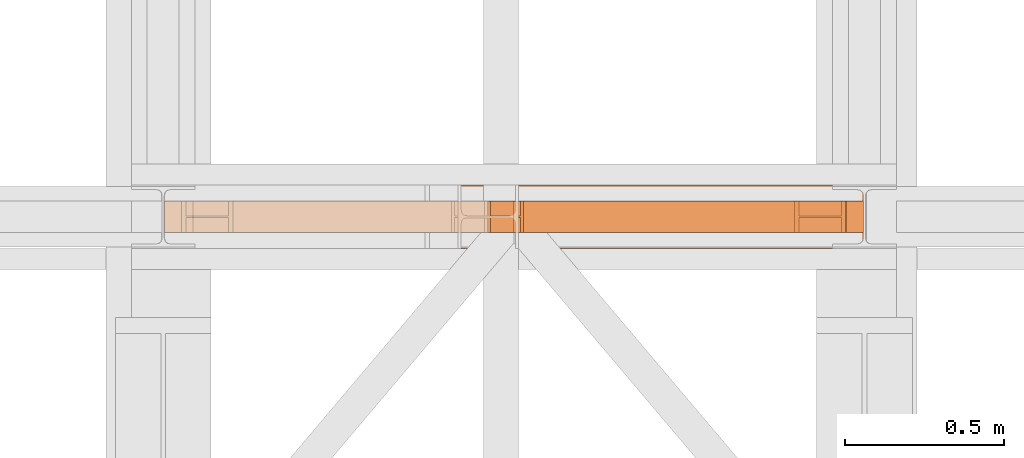
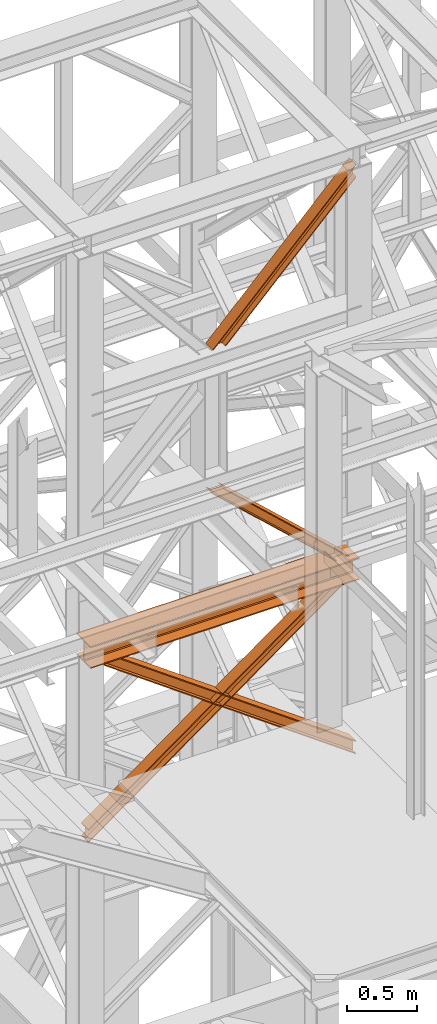
# One storey, part 110 of 208: 5 proxies.
"""IFC2X3 building model written with IfcOpenShell, lengths in millimetres."""

from ifc_helpers import new_model, entity, si_unit, converted_unit, frame, origin, origin_with_axes, place, context, subcontext, project, spatial, faceted_brep, element, save


model = new_model("IFC2X3")

# Units and contexts
model_context = context("Model", 3, precision=1e-05, world=origin())
plan_context = context("Plan", 3, precision=1e-05, world=origin())
body_context = subcontext(model_context, "Body", "Model", "MODEL_VIEW")
ifc_project = project(units=[si_unit("LENGTHUNIT", "METRE", prefix="MILLI"), converted_unit("PLANEANGLEUNIT", "DEGREE", entity("IfcPlaneAngleMeasure", 0.0174532925199433), si_unit("PLANEANGLEUNIT", "RADIAN"), dimensions=[0, 0, 0, 0, 0, 0, 0]), si_unit("AREAUNIT", "SQUARE_METRE"), si_unit("VOLUMEUNIT", "CUBIC_METRE")], contexts=[model_context, plan_context])

# Building, storey
building_placement = place(None, origin())
building = spatial("IfcBuilding", under=ifc_project, at=building_placement, CompositionType="COMPLEX")
storey_placement = place(building_placement, origin_with_axes())
storey = spatial("IfcBuildingStorey", under=building, at=storey_placement, Name="Geschoss", CompositionType="ELEMENT")

# Proxies
proxy_1_placement = place(storey_placement, frame((-14.99503153838828, -16062.574391808, 8678.7992121432), z_axis=(0.0, 0.0, 1.0), x_axis=(1.0, 0.0, 0.0)))
element("IfcBuildingElementProxy", 1, at=proxy_1_placement, inside=storey, context=body_context, shape_type="Brep", body=[
    faceted_brep([(0.009999999999990905, 0.01000000000021828, 0.01000000000021828), (0.009999999999990905, 200.0100029802325, 0.01000000000021828), (0.009999999999990905, 200.0100029802325, 10.00999791383765), (0.009999999999990905, 121.2600035762789, 10.01000536441825), (0.009999999999990905, 111.9441915473344, 11.87455041170142), (0.009999999999990905, 105.1245498640838, 18.69419349193595), (0.009999999999990905, 103.2600015571716, 28.01000458955787), (0.009999999999990905, 103.2600015571716, 162.0100153779986), (0.009999999999990905, 105.1245498640838, 171.3258264756205), (0.009999999999990905, 111.9441915473344, 178.145469555855), (0.009999999999990905, 121.2600035762789, 180.0100146031382), (0.009999999999990905, 200.0100029802325, 180.0100146031382), (0.009999999999990905, 200.0100029802325, 190.0100125169756), (0.009999999999990905, 0.01000000000021828, 190.0100125169756), (0.009999999999990905, 0.01000000000021828, 180.0100146031382), (0.009999999999990905, 78.75999940395377, 180.0100146031382), (0.009999999999990905, 88.07581143289826, 178.145469555855), (0.009999999999990905, 94.89545311614893, 171.3258264756205), (0.009999999999990905, 96.76000142306111, 162.0100153779986), (0.009999999999990905, 96.76000142306111, 28.01000458955787), (0.009999999999990905, 94.89545311614893, 18.69419349193595), (0.009999999999990905, 88.07581143289826, 11.87455041170142), (0.009999999999990905, 78.75999940395377, 10.01000536441825), (0.009999999999990905, 0.01000000000021828, 10.00999791383765), (0.009999999999990905, 200.0100029802325, 0.01000000000021828), (0.009999999999990905, 0.01000000000021828, 0.01000000000021828), (2205.009999999998, 0.00999999999839929, 0.01000000000021828), (2205.009999999998, 200.0100029802306, 0.01000000000021828), (0.009999999999990905, 200.0100029802325, 10.00999791383765), (0.009999999999990905, 200.0100029802325, 0.01000000000021828), (2205.009999999998, 200.0100029802306, 0.01000000000021828), (2205.009999999998, 200.0100029802306, 10.00999791383765), (0.009999999999990905, 121.2600035762789, 10.01000536441825), (0.009999999999990905, 200.0100029802325, 10.00999791383765), (2205.009999999998, 200.0100029802306, 10.00999791383765), (2205.009999999998, 121.2600035762771, 10.01000536441825), (0.009999999999990905, 111.9441915473344, 11.87455041170142), (0.009999999999990905, 121.2600035762789, 10.01000536441825), (2205.009999999998, 121.2600035762771, 10.01000536441825), (2205.009999999998, 111.9441915473326, 11.87455041170142), (0.009999999999990905, 105.1245498640838, 18.69419349193595), (0.009999999999990905, 111.9441915473344, 11.87455041170142), (2205.009999999998, 111.9441915473326, 11.87455041170142), (2205.009999999998, 105.1245498640819, 18.69419349193595), (0.009999999999990905, 103.2600015571716, 28.01000458955787), (0.009999999999990905, 105.1245498640838, 18.69419349193595), (2205.009999999998, 105.1245498640819, 18.69419349193595), (2205.009999999998, 103.2600015571697, 28.01000458955787), (0.009999999999990905, 103.2600015571716, 162.0100153779986), (0.009999999999990905, 103.2600015571716, 28.01000458955787), (2205.009999999998, 103.2600015571697, 28.01000458955787), (2205.009999999998, 103.2600015571697, 162.0100153779986), (0.009999999999990905, 105.1245498640838, 171.3258264756205), (0.009999999999990905, 103.2600015571716, 162.0100153779986), (2205.009999999998, 103.2600015571697, 162.0100153779986), (2205.009999999998, 105.1245498640819, 171.3258264756205), (0.009999999999990905, 111.9441915473344, 178.145469555855), (0.009999999999990905, 105.1245498640838, 171.3258264756205), (2205.009999999998, 105.1245498640819, 171.3258264756205), (2205.009999999998, 111.9441915473326, 178.145469555855), (0.009999999999990905, 121.2600035762789, 180.0100146031382), (0.009999999999990905, 111.9441915473344, 178.145469555855), (2205.009999999998, 111.9441915473326, 178.145469555855), (2205.009999999998, 121.2600035762771, 180.0100146031382), (0.009999999999990905, 200.0100029802325, 180.0100146031382), (0.009999999999990905, 121.2600035762789, 180.0100146031382), (2205.009999999998, 121.2600035762771, 180.0100146031382), (2205.009999999998, 200.0100029802306, 180.0100146031382), (0.009999999999990905, 200.0100029802325, 190.0100125169756), (0.009999999999990905, 200.0100029802325, 180.0100146031382), (2205.009999999998, 200.0100029802306, 180.0100146031382), (2205.009999999998, 200.0100029802306, 190.0100125169756), (0.009999999999990905, 0.01000000000021828, 190.0100125169756), (0.009999999999990905, 200.0100029802325, 190.0100125169756), (2205.009999999998, 200.0100029802306, 190.0100125169756), (2205.009999999998, 0.00999999999839929, 190.0100125169756), (0.009999999999990905, 0.01000000000021828, 180.0100146031382), (0.009999999999990905, 0.01000000000021828, 190.0100125169756), (2205.009999999998, 0.00999999999839929, 190.0100125169756), (2205.009999999998, 0.00999999999839929, 180.0100146031382), (0.009999999999990905, 78.75999940395377, 180.0100146031382), (0.009999999999990905, 0.01000000000021828, 180.0100146031382), (2205.009999999998, 0.00999999999839929, 180.0100146031382), (2205.009999999998, 78.75999940395195, 180.0100146031382), (0.009999999999990905, 88.07581143289826, 178.145469555855), (0.009999999999990905, 78.75999940395377, 180.0100146031382), (2205.009999999998, 78.75999940395195, 180.0100146031382), (2205.009999999998, 88.07581143289644, 178.145469555855), (0.009999999999990905, 94.89545311614893, 171.3258264756205), (0.009999999999990905, 88.07581143289826, 178.145469555855), (2205.009999999998, 88.07581143289644, 178.145469555855), (2205.009999999998, 94.89545311614711, 171.3258264756205), (0.009999999999990905, 96.76000142306111, 162.0100153779986), (0.009999999999990905, 94.89545311614893, 171.3258264756205), (2205.009999999998, 94.89545311614711, 171.3258264756205), (2205.009999999998, 96.7600014230593, 162.0100153779986), (0.009999999999990905, 96.76000142306111, 28.01000458955787), (0.009999999999990905, 96.76000142306111, 162.0100153779986), (2205.009999999998, 96.7600014230593, 162.0100153779986), (2205.009999999998, 96.7600014230593, 28.01000458955787), (0.009999999999990905, 94.89545311614893, 18.69419349193595), (0.009999999999990905, 96.76000142306111, 28.01000458955787), (2205.009999999998, 96.7600014230593, 28.01000458955787), (2205.009999999998, 94.89545311614711, 18.69419349193595), (0.009999999999990905, 88.07581143289826, 11.87455041170142), (0.009999999999990905, 94.89545311614893, 18.69419349193595), (2205.009999999998, 94.89545311614711, 18.69419349193595), (2205.009999999998, 88.07581143289644, 11.87455041170142), (0.009999999999990905, 78.75999940395377, 10.01000536441825), (0.009999999999990905, 88.07581143289826, 11.87455041170142), (2205.009999999998, 88.07581143289644, 11.87455041170142), (2205.009999999998, 78.75999940395195, 10.01000536441825), (0.009999999999990905, 0.01000000000021828, 10.00999791383765), (0.009999999999990905, 78.75999940395377, 10.01000536441825), (2205.009999999998, 78.75999940395195, 10.01000536441825), (2205.009999999998, 0.00999999999839929, 10.00999791383765), (0.009999999999990905, 0.01000000000021828, 0.01000000000021828), (0.009999999999990905, 0.01000000000021828, 10.00999791383765), (2205.009999999998, 0.00999999999839929, 10.00999791383765), (2205.009999999998, 0.00999999999839929, 0.01000000000021828), (2205.009999999998, 0.00999999999839929, 0.01000000000021828), (2205.009999999998, 0.00999999999839929, 10.00999791383765), (2205.009999999998, 78.75999940395195, 10.01000536441825), (2205.009999999998, 88.07581143289644, 11.87455041170142), (2205.009999999998, 94.89545311614711, 18.69419349193595), (2205.009999999998, 96.7600014230593, 28.01000458955787), (2205.009999999998, 96.7600014230593, 162.0100153779986), (2205.009999999998, 94.89545311614711, 171.3258264756205), (2205.009999999998, 88.07581143289644, 178.145469555855), (2205.009999999998, 78.75999940395195, 180.0100146031382), (2205.009999999998, 0.00999999999839929, 180.0100146031382), (2205.009999999998, 0.00999999999839929, 190.0100125169756), (2205.009999999998, 200.0100029802306, 190.0100125169756), (2205.009999999998, 200.0100029802306, 180.0100146031382), (2205.009999999998, 121.2600035762771, 180.0100146031382), (2205.009999999998, 111.9441915473326, 178.145469555855), (2205.009999999998, 105.1245498640819, 171.3258264756205), (2205.009999999998, 103.2600015571697, 162.0100153779986), (2205.009999999998, 103.2600015571697, 28.01000458955787), (2205.009999999998, 105.1245498640819, 18.69419349193595), (2205.009999999998, 111.9441915473326, 11.87455041170142), (2205.009999999998, 121.2600035762771, 10.01000536441825), (2205.009999999998, 200.0100029802306, 10.00999791383765), (2205.009999999998, 200.0100029802306, 0.01000000000021828)], [[[0, 1, 2, 3, 4, 5, 6, 7, 8, 9, 10, 11, 12, 13, 14, 15, 16, 17, 18, 19, 20, 21, 22, 23]], [[24, 25, 26, 27]], [[28, 29, 30, 31]], [[32, 33, 34, 35]], [[36, 37, 38, 39]], [[40, 41, 42, 43]], [[44, 45, 46, 47]], [[48, 49, 50, 51]], [[52, 53, 54, 55]], [[56, 57, 58, 59]], [[60, 61, 62, 63]], [[64, 65, 66, 67]], [[68, 69, 70, 71]], [[72, 73, 74, 75]], [[76, 77, 78, 79]], [[80, 81, 82, 83]], [[84, 85, 86, 87]], [[88, 89, 90, 91]], [[92, 93, 94, 95]], [[96, 97, 98, 99]], [[100, 101, 102, 103]], [[104, 105, 106, 107]], [[108, 109, 110, 111]], [[112, 113, 114, 115]], [[116, 117, 118, 119]], [[120, 121, 122, 123, 124, 125, 126, 127, 128, 129, 130, 131, 132, 133, 134, 135, 136, 137, 138, 139, 140, 141, 142, 143]]], orient=[[False], [False], [False], [False], [False], [False], [False], [False], [False], [False], [False], [False], [False], [False], [False], [False], [False], [False], [False], [False], [False], [False], [False], [False], [False], [False]]),
])
proxy_2_placement = place(storey_placement, frame((1010.292894340123, -16012.57439031789, 8868.799224660175), z_axis=(0.0, 0.0, 1.0), x_axis=(1.0, 0.0, 0.0)))
element("IfcBuildingElementProxy", 2, at=proxy_2_placement, inside=storey, context=body_context, shape_type="Brep", body=[
    faceted_brep([(9.449425091078183, 0.01000000000021828, 935.2008089996834), (1021.156553720136, 0.01000000000021828, 0.01000000000203727), (1011.717128629058, 0.01000000000021828, 0.01000000000203727), (0.009999999999990905, 0.01000000000021828, 935.2008089996816), (0.009999999999990905, 0.01000000000021828, 935.2008089996816), (1011.717128629058, 0.01000000000021828, 0.01000000000203727), (1011.717128629056, 100.0100000000002, 0.01000000000203727), (0.009999999999990905, 100.0100000000002, 935.2008089996816), (0.009999999999990905, 100.0100000000002, 935.2008089996816), (1011.717128629056, 100.0100000000002, 0.01000000000203727), (1021.156553720136, 100.0100000000002, 0.01000000000203727), (9.449425091079092, 100.0100000000002, 935.2008089996834), (9.449425091079092, 100.0100000000002, 935.2008089996834), (1021.156553720136, 100.0100000000002, 0.01000000000203727), (1021.156553720136, 52.51000000000022, 0.01000000000203727), (9.449425091079092, 52.51000000000022, 935.2008089996834), (9.449425091079092, 52.51000000000022, 935.2008089996834), (1021.156553720136, 52.51000000000022, 0.01000000000203727), (1115.550804630939, 52.51000000000022, 0.01000000000203727), (103.8436760018838, 52.51000000000022, 935.2008089996816), (103.8436760018838, 52.51000000000022, 935.2008089996816), (1115.550804630939, 52.51000000000022, 0.01000000000203727), (1115.550804630941, 100.0100000000002, 0.01000000000203727), (103.8436760018819, 100.0100000000002, 935.2008089996816), (103.8436760018819, 100.0100000000002, 935.2008089996816), (1115.550804630941, 100.0100000000002, 0.01000000000203727), (1124.99022972202, 100.0100000000002, 0.01000000000203727), (113.2831010929638, 100.0100000000002, 935.2008089996816), (113.2831010929638, 100.0100000000002, 935.2008089996816), (1124.99022972202, 100.0100000000002, 0.01000000000203727), (1124.99022972202, 0.01000000000021828, 0.01000000000385626), (113.2831010929647, 0.01000000000021828, 935.2008089996816), (113.2831010929647, 0.01000000000021828, 935.2008089996816), (1124.99022972202, 0.01000000000021828, 0.01000000000385626), (1115.550804630942, 0.01000000000021828, 0.01000000000021828), (103.8436760018838, 0.01000000000021828, 935.2008089996816), (103.8436760018838, 0.01000000000021828, 935.2008089996816), (1115.550804630942, 0.01000000000021828, 0.01000000000021828), (1115.550804630939, 47.51000000000022, 0.01000000000203727), (103.8436760018819, 47.51000000000022, 935.2008089996816), (103.8436760018819, 47.51000000000022, 935.2008089996816), (1115.550804630939, 47.51000000000022, 0.01000000000203727), (1021.156553720136, 47.51000000000022, 0.01000000000203727), (9.449425091079092, 47.51000000000022, 935.2008089996834), (9.449425091079092, 47.51000000000022, 935.2008089996834), (1021.156553720136, 47.51000000000022, 0.01000000000203727), (1021.156553720136, 0.01000000000021828, 0.01000000000203727), (9.449425091078183, 0.01000000000021828, 935.2008089996834), (0.009999999999990905, 0.01000000000021828, 935.2008089996816), (0.009999999999990905, 100.0100000000002, 935.2008089996816), (9.449425091079092, 100.0100000000002, 935.2008089996834), (9.449425091079092, 52.51000000000022, 935.2008089996834), (103.8436760018838, 52.51000000000022, 935.2008089996816), (103.8436760018819, 100.0100000000002, 935.2008089996816), (113.2831010929638, 100.0100000000002, 935.2008089996816), (113.2831010929647, 0.01000000000021828, 935.2008089996816), (103.8436760018838, 0.01000000000021828, 935.2008089996816), (103.8436760018819, 47.51000000000022, 935.2008089996816), (9.449425091079092, 47.51000000000022, 935.2008089996834), (9.449425091078183, 0.01000000000021828, 935.2008089996834), (1021.156553720136, 0.01000000000021828, 0.01000000000203727), (1021.156553720136, 47.51000000000022, 0.01000000000203727), (1115.550804630939, 47.51000000000022, 0.01000000000203727), (1115.550804630942, 0.01000000000021828, 0.01000000000021828), (1124.99022972202, 0.01000000000021828, 0.01000000000385626), (1124.99022972202, 100.0100000000002, 0.01000000000203727), (1115.550804630941, 100.0100000000002, 0.01000000000203727), (1115.550804630939, 52.51000000000022, 0.01000000000203727), (1021.156553720136, 52.51000000000022, 0.01000000000203727), (1021.156553720136, 100.0100000000002, 0.01000000000203727), (1011.717128629056, 100.0100000000002, 0.01000000000203727), (1011.717128629058, 0.01000000000021828, 0.01000000000203727)], [[[0, 1, 2, 3]], [[4, 5, 6, 7]], [[8, 9, 10, 11]], [[12, 13, 14, 15]], [[16, 17, 18, 19]], [[20, 21, 22, 23]], [[24, 25, 26, 27]], [[28, 29, 30, 31]], [[32, 33, 34, 35]], [[36, 37, 38, 39]], [[40, 41, 42, 43]], [[44, 45, 46, 47]], [[48, 49, 50, 51, 52, 53, 54, 55, 56, 57, 58, 59]], [[60, 61, 62, 63, 64, 65, 66, 67, 68, 69, 70, 71]]], orient=[[False], [False], [False], [False], [False], [False], [False], [False], [False], [False], [False], [False], [False], [False]]),
])
proxy_3_placement = place(storey_placement, frame((1013.254957054771, -16012.57439031789, 11048.99005869381), z_axis=(0.0, 0.0, 1.0), x_axis=(1.0, 0.0, 0.0)))
element("IfcBuildingElementProxy", 3, at=proxy_3_placement, inside=storey, context=body_context, shape_type="Brep", body=[
    faceted_brep([(9.449425091078183, 0.01000000000021828, 0.01000000000021828), (0.009999999999990905, 0.01000000000021828, 0.01000000000203727), (1176.760011406839, 0.01000000000021828, 1201.010000000002), (1176.760011406839, 0.01000000000021828, 1191.327434941319), (0.009999999999990905, 0.01000000000021828, 0.01000000000203727), (0.009999999999990905, 100.0100000000002, 0.01000000000203727), (1176.760011406839, 100.0100000000002, 1201.010000000004), (1176.760011406839, 0.01000000000021828, 1201.010000000002), (0.009999999999990905, 100.0100000000002, 0.01000000000203727), (9.449425091079092, 100.0100000000002, 0.01000000000021828), (1176.760011406839, 100.0100000000002, 1191.327434941319), (1176.760011406839, 100.0100000000002, 1201.010000000004), (9.449425091079092, 100.0100000000002, 0.01000000000021828), (9.449425091079092, 52.51000000000022, 0.01000000000021828), (1176.760011406839, 52.51000000000022, 1191.327434941319), (1176.760011406839, 100.0100000000002, 1191.327434941319), (9.449425091079092, 52.51000000000022, 0.01000000000021828), (103.8436760018838, 52.51000000000022, 0.01000000000203727), (1176.760011406837, 52.51000000000022, 1094.501784354448), (1176.760011406839, 52.51000000000022, 1191.327434941319), (103.8436760018838, 52.51000000000022, 0.01000000000203727), (103.8436760018819, 100.0100000000002, 0.01000000000203727), (1176.760011406839, 100.0100000000002, 1094.501784354448), (1176.760011406837, 52.51000000000022, 1094.501784354448), (103.8436760018819, 100.0100000000002, 0.01000000000203727), (113.2831010929638, 100.0100000000002, 0.01000000000203727), (1176.760011406837, 100.0100000000002, 1084.819219295761), (1176.760011406839, 100.0100000000002, 1094.501784354448), (113.2831010929638, 100.0100000000002, 0.01000000000203727), (113.2831010929647, 0.01000000000021828, 0.01000000000203727), (1176.760011406839, 0.01000000000021828, 1084.819219295761), (1176.760011406837, 100.0100000000002, 1084.819219295761), (113.2831010929647, 0.01000000000021828, 0.01000000000203727), (103.8436760018838, 0.01000000000021828, 0.01000000000203727), (1176.760011406839, 0.01000000000021828, 1094.501784354448), (1176.760011406839, 0.01000000000021828, 1084.819219295761), (103.8436760018838, 0.01000000000021828, 0.01000000000203727), (103.8436760018819, 47.51000000000022, 0.01000000000203727), (1176.760011406839, 47.51000000000022, 1094.50178435445), (1176.760011406839, 0.01000000000021828, 1094.501784354448), (103.8436760018819, 47.51000000000022, 0.01000000000203727), (9.449425091079092, 47.51000000000022, 0.01000000000021828), (1176.760011406839, 47.51000000000022, 1191.327434941319), (1176.760011406839, 47.51000000000022, 1094.50178435445), (9.449425091079092, 47.51000000000022, 0.01000000000021828), (9.449425091078183, 0.01000000000021828, 0.01000000000021828), (1176.760011406839, 0.01000000000021828, 1191.327434941319), (1176.760011406839, 47.51000000000022, 1191.327434941319), (1176.760011406839, 0.01000000000021828, 1191.327434941319), (1176.760011406839, 0.01000000000021828, 1201.010000000002), (1176.760011406839, 100.0100000000002, 1201.010000000004), (1176.760011406839, 100.0100000000002, 1191.327434941319), (1176.760011406839, 52.51000000000022, 1191.327434941319), (1176.760011406837, 52.51000000000022, 1094.501784354448), (1176.760011406839, 100.0100000000002, 1094.501784354448), (1176.760011406837, 100.0100000000002, 1084.819219295761), (1176.760011406839, 0.01000000000021828, 1084.819219295761), (1176.760011406839, 0.01000000000021828, 1094.501784354448), (1176.760011406839, 47.51000000000022, 1094.50178435445), (1176.760011406839, 47.51000000000022, 1191.327434941319), (0.009999999999990905, 0.01000000000021828, 0.01000000000203727), (9.449425091078183, 0.01000000000021828, 0.01000000000021828), (9.449425091079092, 47.51000000000022, 0.01000000000021828), (103.8436760018819, 47.51000000000022, 0.01000000000203727), (103.8436760018838, 0.01000000000021828, 0.01000000000203727), (113.2831010929647, 0.01000000000021828, 0.01000000000203727), (113.2831010929638, 100.0100000000002, 0.01000000000203727), (103.8436760018819, 100.0100000000002, 0.01000000000203727), (103.8436760018838, 52.51000000000022, 0.01000000000203727), (9.449425091079092, 52.51000000000022, 0.01000000000021828), (9.449425091079092, 100.0100000000002, 0.01000000000021828), (0.009999999999990905, 100.0100000000002, 0.01000000000203727)], [[[0, 1, 2, 3]], [[4, 5, 6, 7]], [[8, 9, 10, 11]], [[12, 13, 14, 15]], [[16, 17, 18, 19]], [[20, 21, 22, 23]], [[24, 25, 26, 27]], [[28, 29, 30, 31]], [[32, 33, 34, 35]], [[36, 37, 38, 39]], [[40, 41, 42, 43]], [[44, 45, 46, 47]], [[48, 49, 50, 51, 52, 53, 54, 55, 56, 57, 58, 59]], [[60, 61, 62, 63, 64, 65, 66, 67, 68, 69, 70, 71]]], orient=[[False], [False], [False], [False], [False], [False], [False], [False], [False], [False], [False], [False], [False], [False]]),
])
proxy_4_placement = place(storey_placement, frame((-4.245031471320317, -16012.57439031789, 7134.990005364418), z_axis=(0.0, 0.0, 1.0), x_axis=(1.0, 0.0, 0.0)))
element("IfcBuildingElementProxy", 4, at=proxy_4_placement, inside=storey, context=body_context, shape_type="Brep", body=[
    faceted_brep([(2139.107323533797, 0.01000000000021828, 1544.010028295439), (0.009999999999990905, 0.01000000000021828, 0.01000000000112777), (0.009999999999990905, 0.01000000000021828, 9.69256505868816), (2125.692849037419, 0.01000000000021828, 1544.010028295439), (2139.107323533799, 100.0100000000002, 1544.010028295439), (0.009999999999990905, 100.0100000000002, 0.01000000000021828), (0.009999999999990905, 0.01000000000021828, 0.01000000000112777), (2139.107323533797, 0.01000000000021828, 1544.010028295439), (2125.692849037419, 100.0100000000002, 1544.010028295439), (0.009999999999990905, 100.0100000000002, 9.69256505868816), (0.009999999999990905, 100.0100000000002, 0.01000000000021828), (2139.107323533799, 100.0100000000002, 1544.010028295439), (2125.692849037419, 52.51000000000022, 1544.010028295439), (0.009999999999990905, 52.51000000000022, 9.69256505868816), (0.009999999999990905, 100.0100000000002, 9.69256505868816), (2125.692849037419, 100.0100000000002, 1544.010028295439), (1991.548104073622, 52.51000000000022, 1544.010028295439), (0.009999999999990905, 52.51000000000022, 106.5182156455558), (0.009999999999990905, 52.51000000000022, 9.69256505868816), (2125.692849037419, 52.51000000000022, 1544.010028295439), (1991.548104073623, 100.0100000000002, 1544.010028295439), (0.01000000000180989, 100.0100000000002, 106.5182156455558), (0.009999999999990905, 52.51000000000022, 106.5182156455558), (1991.548104073622, 52.51000000000022, 1544.010028295439), (1978.133629577241, 100.0100000000002, 1544.010028295439), (0.009999999999990905, 100.0100000000002, 116.2007807042428), (0.01000000000180989, 100.0100000000002, 106.5182156455558), (1991.548104073623, 100.0100000000002, 1544.010028295439), (1978.133629577238, 0.01000000000021828, 1544.010028295439), (0.009999999999990905, 0.01000000000021828, 116.2007807042428), (0.009999999999990905, 100.0100000000002, 116.2007807042428), (1978.133629577241, 100.0100000000002, 1544.010028295439), (1991.548104073623, 0.01000000000021828, 1544.010028295439), (0.009999999999990905, 0.01000000000021828, 106.5182156455549), (0.009999999999990905, 0.01000000000021828, 116.2007807042428), (1978.133629577238, 0.01000000000021828, 1544.010028295439), (1991.548104073622, 47.51000000000022, 1544.010028295439), (0.009999999999990905, 47.51000000000022, 106.5182156455549), (0.009999999999990905, 0.01000000000021828, 106.5182156455549), (1991.548104073623, 0.01000000000021828, 1544.010028295439), (2125.692849037419, 47.51000000000022, 1544.010028295439), (0.009999999999990905, 47.51000000000022, 9.69256505868816), (0.009999999999990905, 47.51000000000022, 106.5182156455549), (1991.548104073622, 47.51000000000022, 1544.010028295439), (2125.692849037419, 0.01000000000021828, 1544.010028295439), (0.009999999999990905, 0.01000000000021828, 9.69256505868816), (0.009999999999990905, 47.51000000000022, 9.69256505868816), (2125.692849037419, 47.51000000000022, 1544.010028295439), (0.009999999999990905, 0.01000000000021828, 0.01000000000112777), (0.009999999999990905, 100.0100000000002, 0.01000000000021828), (0.009999999999990905, 100.0100000000002, 9.69256505868816), (0.009999999999990905, 52.51000000000022, 9.69256505868816), (0.009999999999990905, 52.51000000000022, 106.5182156455558), (0.01000000000180989, 100.0100000000002, 106.5182156455558), (0.009999999999990905, 100.0100000000002, 116.2007807042428), (0.009999999999990905, 0.01000000000021828, 116.2007807042428), (0.009999999999990905, 0.01000000000021828, 106.5182156455549), (0.009999999999990905, 47.51000000000022, 106.5182156455549), (0.009999999999990905, 47.51000000000022, 9.69256505868816), (0.009999999999990905, 0.01000000000021828, 9.69256505868816), (2125.692849037419, 0.01000000000021828, 1544.010028295439), (2125.692849037419, 47.51000000000022, 1544.010028295439), (1991.548104073622, 47.51000000000022, 1544.010028295439), (1991.548104073623, 0.01000000000021828, 1544.010028295439), (1978.133629577238, 0.01000000000021828, 1544.010028295439), (1978.133629577241, 100.0100000000002, 1544.010028295439), (1991.548104073623, 100.0100000000002, 1544.010028295439), (1991.548104073622, 52.51000000000022, 1544.010028295439), (2125.692849037419, 52.51000000000022, 1544.010028295439), (2125.692849037419, 100.0100000000002, 1544.010028295439), (2139.107323533799, 100.0100000000002, 1544.010028295439), (2139.107323533797, 0.01000000000021828, 1544.010028295439)], [[[0, 1, 2, 3]], [[4, 5, 6, 7]], [[8, 9, 10, 11]], [[12, 13, 14, 15]], [[16, 17, 18, 19]], [[20, 21, 22, 23]], [[24, 25, 26, 27]], [[28, 29, 30, 31]], [[32, 33, 34, 35]], [[36, 37, 38, 39]], [[40, 41, 42, 43]], [[44, 45, 46, 47]], [[48, 49, 50, 51, 52, 53, 54, 55, 56, 57, 58, 59]], [[60, 61, 62, 63, 64, 65, 66, 67, 68, 69, 70, 71]]], orient=[[False], [False], [False], [False], [False], [False], [False], [False], [False], [False], [False], [False], [False], [False]]),
])
proxy_5_placement = place(storey_placement, frame((51.17201396153382, -16012.57439031789, 7134.990005364418), z_axis=(0.0, 0.0, 1.0), x_axis=(1.0, 0.0, 0.0)))
element("IfcBuildingElementProxy", 5, at=proxy_5_placement, inside=storey, context=body_context, shape_type="Brep", body=[
    faceted_brep([(13.42447449638144, 0.01000000000021828, 1543.819206778784), (2138.842954500076, 0.01000000000021828, 9.692565058686341), (2138.842954500076, 0.01000000000021828, 0.01000000000112777), (0.009999999999990905, 0.01000000000021828, 1543.819206778784), (0.009999999999990905, 0.01000000000021828, 1543.819206778784), (2138.842954500076, 0.01000000000021828, 0.01000000000112777), (2138.842954500076, 100.0100000000002, 0.01000000000021828), (0.01000000000180989, 100.0100000000002, 1543.819206778782), (0.01000000000180989, 100.0100000000002, 1543.819206778782), (2138.842954500076, 100.0100000000002, 0.01000000000021828), (2138.842954500076, 100.0100000000002, 9.692565058686341), (13.42447449638144, 100.0100000000002, 1543.819206778784), (13.42447449638144, 100.0100000000002, 1543.819206778784), (2138.842954500076, 100.0100000000002, 9.692565058686341), (2138.842954500076, 52.51000000000022, 9.692565058686341), (13.42447449637962, 52.51000000000022, 1543.819206778786), (13.42447449637962, 52.51000000000022, 1543.819206778786), (2138.842954500076, 52.51000000000022, 9.692565058686341), (2138.842954500075, 52.51000000000022, 106.5182156455549), (147.5692194601777, 52.51000000000022, 1543.819206778784), (147.5692194601777, 52.51000000000022, 1543.819206778784), (2138.842954500075, 52.51000000000022, 106.5182156455549), (2138.842954500076, 100.0100000000002, 106.5182156455549), (147.5692194601777, 100.0100000000002, 1543.819206778782), (147.5692194601777, 100.0100000000002, 1543.819206778782), (2138.842954500076, 100.0100000000002, 106.5182156455549), (2138.842954500075, 100.0100000000002, 116.2007807042419), (160.9836939565591, 100.0100000000002, 1543.819206778784), (160.9836939565591, 100.0100000000002, 1543.819206778784), (2138.842954500075, 100.0100000000002, 116.2007807042419), (2138.842954500076, 0.01000000000021828, 116.2007807042419), (160.9836939565591, 0.01000000000021828, 1543.819206778784), (160.9836939565591, 0.01000000000021828, 1543.819206778784), (2138.842954500076, 0.01000000000021828, 116.2007807042419), (2138.842954500076, 0.01000000000021828, 106.5182156455549), (147.5692194601777, 0.01000000000021828, 1543.819206778784), (147.5692194601777, 0.01000000000021828, 1543.819206778784), (2138.842954500076, 0.01000000000021828, 106.5182156455549), (2138.842954500076, 47.51000000000022, 106.5182156455539), (147.5692194601777, 47.51000000000022, 1543.819206778782), (147.5692194601777, 47.51000000000022, 1543.819206778782), (2138.842954500076, 47.51000000000022, 106.5182156455539), (2138.842954500076, 47.51000000000022, 9.692565058686341), (13.42447449638144, 47.51000000000022, 1543.819206778784), (13.42447449638144, 47.51000000000022, 1543.819206778784), (2138.842954500076, 47.51000000000022, 9.692565058686341), (2138.842954500076, 0.01000000000021828, 9.692565058686341), (13.42447449638144, 0.01000000000021828, 1543.819206778784), (2138.842954500076, 0.01000000000021828, 9.692565058686341), (2138.842954500076, 47.51000000000022, 9.692565058686341), (2138.842954500076, 47.51000000000022, 106.5182156455539), (2138.842954500076, 0.01000000000021828, 106.5182156455549), (2138.842954500076, 0.01000000000021828, 116.2007807042419), (2138.842954500075, 100.0100000000002, 116.2007807042419), (2138.842954500076, 100.0100000000002, 106.5182156455549), (2138.842954500075, 52.51000000000022, 106.5182156455549), (2138.842954500076, 52.51000000000022, 9.692565058686341), (2138.842954500076, 100.0100000000002, 9.692565058686341), (2138.842954500076, 100.0100000000002, 0.01000000000021828), (2138.842954500076, 0.01000000000021828, 0.01000000000112777), (0.009999999999990905, 0.01000000000021828, 1543.819206778784), (0.01000000000180989, 100.0100000000002, 1543.819206778782), (13.42447449638144, 100.0100000000002, 1543.819206778784), (13.42447449637962, 52.51000000000022, 1543.819206778786), (147.5692194601777, 52.51000000000022, 1543.819206778784), (147.5692194601777, 100.0100000000002, 1543.819206778782), (160.9836939565591, 100.0100000000002, 1543.819206778784), (160.9836939565591, 0.01000000000021828, 1543.819206778784), (147.5692194601777, 0.01000000000021828, 1543.819206778784), (147.5692194601777, 47.51000000000022, 1543.819206778782), (13.42447449638144, 47.51000000000022, 1543.819206778784), (13.42447449638144, 0.01000000000021828, 1543.819206778784)], [[[0, 1, 2, 3]], [[4, 5, 6, 7]], [[8, 9, 10, 11]], [[12, 13, 14, 15]], [[16, 17, 18, 19]], [[20, 21, 22, 23]], [[24, 25, 26, 27]], [[28, 29, 30, 31]], [[32, 33, 34, 35]], [[36, 37, 38, 39]], [[40, 41, 42, 43]], [[44, 45, 46, 47]], [[48, 49, 50, 51, 52, 53, 54, 55, 56, 57, 58, 59]], [[60, 61, 62, 63, 64, 65, 66, 67, 68, 69, 70, 71]]], orient=[[False], [False], [False], [False], [False], [False], [False], [False], [False], [False], [False], [False], [False], [False]]),
])

save(model, "model.ifc")
